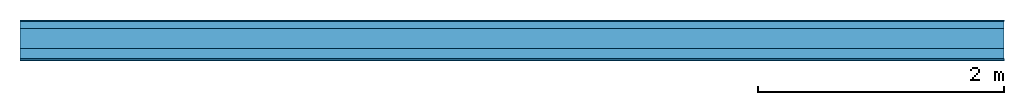
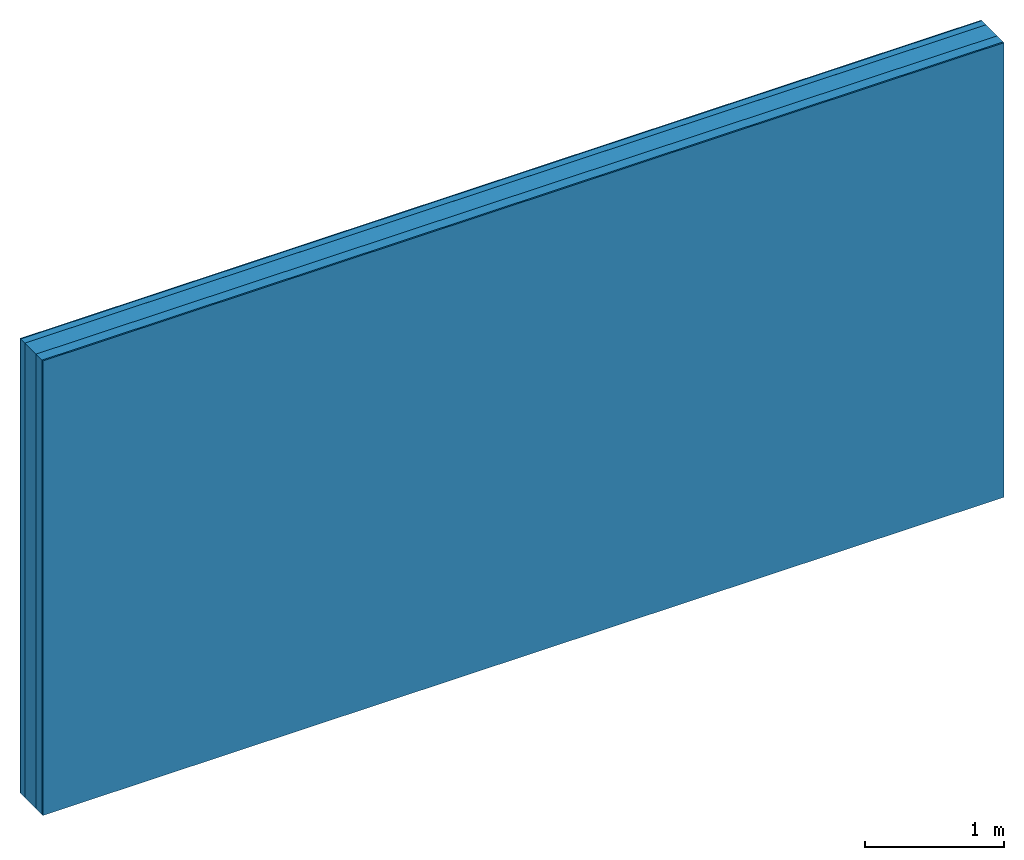
# One storey: 4 plates, 1 member, 1 element without a shape of its own.
"""IFC4 building model written with IfcOpenShell, lengths in metres."""

import ifcopenshell
import ifcopenshell.guid

model = None  # the IFC model being written
_history = None  # IfcOwnerHistory: only IFC2X3 demands one
_inside = {}  # id of a spatial element -> (the spatial element, [elements in it])
_under = {}  # id of a project, library or spatial element -> (it, [spatial elements below it])
_declared = {}  # id of a project -> (the project, [libraries it declares])
_typed = {}  # id of a type object -> (the type object, [elements of that type])
_made_of = {}  # id of a material, layer set ... -> (it, [elements and type objects made of it])


def new_model(schema):
    """Start an empty IFC model of exactly this schema.

    Asked for "IFC4X3", IfcOpenShell would pick the latest addendum, in which some entities
    have other attributes; the version numbers below select the first issue.
    IFC2X3 requires an IfcOwnerHistory on every rooted entity: one is made here for all.
    """
    global model, _history
    if schema == "IFC4X3":
        model = ifcopenshell.file(schema_version=(4, 3, 0, 0))
    else:
        model = ifcopenshell.file(schema=schema)
    _inside.clear()
    _under.clear()
    _declared.clear()
    _typed.clear()
    _made_of.clear()
    _history = None
    if model.schema == "IFC2X3":
        org = make("IfcOrganization", Name="unknown")
        user = make(
            "IfcPersonAndOrganization",
            ThePerson=make("IfcPerson", FamilyName="unknown"),
            TheOrganization=org,
        )
        app = make(
            "IfcApplication",
            ApplicationDeveloper=org,
            Version="unknown",
            ApplicationFullName="unknown",
            ApplicationIdentifier="unknown",
        )
        _history = make(
            "IfcOwnerHistory",
            OwningUser=user,
            OwningApplication=app,
            ChangeAction="ADDED",
            CreationDate=0,
        )
    return model


def make(cls, **values):
    """One entity of the class cls with the attributes given. An attribute that is None is left unset."""
    return model.create_entity(
        cls, **{name: value for name, value in values.items() if value is not None}
    )


def rooted(cls, **values):
    """An entity with a GlobalId (a new one), such as an element, a storey or a relation."""
    return make(cls, GlobalId=ifcopenshell.guid.new(), OwnerHistory=_history, **values)


def si_unit(unit_type, name, prefix=None):
    """IfcSIUnit, for example si_unit("LENGTHUNIT", "METRE", prefix="MILLI")."""
    return make("IfcSIUnit", UnitType=unit_type, Prefix=prefix, Name=name)


def derived_unit(unit_type, elements):
    """IfcDerivedUnit: a product of units, each with its exponent."""
    return make(
        "IfcDerivedUnit",
        Elements=[
            make("IfcDerivedUnitElement", Unit=unit, Exponent=power)
            for unit, power in elements
        ],
        UnitType=unit_type,
    )


def assignment(units):
    """IfcUnitAssignment: the units of a project."""
    return None if units is None else make("IfcUnitAssignment", Units=units)


def point(xyz):
    """IfcCartesianPoint."""
    return None if xyz is None else make("IfcCartesianPoint", Coordinates=xyz)


def direction(xyz):
    """IfcDirection."""
    return None if xyz is None else make("IfcDirection", DirectionRatios=xyz)


def frame(location, z_axis=None, x_axis=None):
    """IfcAxis2Placement3D, a coordinate frame: its origin and axes. An axis left out is left unset."""
    return make(
        "IfcAxis2Placement3D",
        Location=point(location),
        Axis=direction(z_axis),
        RefDirection=direction(x_axis),
    )


def frame_2d(location, x_axis=None):
    """IfcAxis2Placement2D, a coordinate frame in the plane: its origin and x axis."""
    return make(
        "IfcAxis2Placement2D", Location=point(location), RefDirection=direction(x_axis)
    )


def origin():
    """The frame at (0, 0, 0) with its axes left unset."""
    return frame((0.0, 0.0, 0.0))


def origin_with_axes():
    """The frame at (0, 0, 0) with the z axis (0, 0, 1) and the x axis (1, 0, 0) written out."""
    return frame((0.0, 0.0, 0.0), z_axis=(0.0, 0.0, 1.0), x_axis=(1.0, 0.0, 0.0))


def place(relative_to, where):
    """IfcLocalPlacement: puts the frame where relative to a parent placement (None: the world)."""
    return make(
        "IfcLocalPlacement", PlacementRelTo=relative_to, RelativePlacement=where
    )


def context(
    kind, dimensions, precision=None, world=None, true_north=None, identifier=None
):
    """IfcGeometricRepresentationContext, for example the 3D "Model" context."""
    return make(
        "IfcGeometricRepresentationContext",
        ContextIdentifier=identifier,
        ContextType=kind,
        CoordinateSpaceDimension=dimensions,
        Precision=precision,
        WorldCoordinateSystem=world,
        TrueNorth=true_north,
    )


def project(units=None, contexts=None):
    """IfcProject with its units and contexts."""
    return rooted(
        "IfcProject",
        Name="project",
        RepresentationContexts=contexts,
        UnitsInContext=assignment(units),
    )


def spatial(cls, under=None, at=None, **own):
    """A site, building, storey or space (cls), placed at a placement, below another one or the project."""
    s = rooted(cls, ObjectPlacement=at, **own)
    if under is not None:
        _under.setdefault(under.id(), (under, []))[1].append(s)
    return s


def profile(cls, at=None, kind="AREA", **sizes):
    """A parametric profile (cls). Its sizes go by their IFC names, for example OverallWidth=200.0."""
    return make(cls, ProfileType=kind, Position=at, **sizes)


def rectangle(**sizes):
    """IfcRectangleProfileDef."""
    return profile("IfcRectangleProfileDef", **sizes)


def extrude(swept, where, along, depth):
    """IfcExtrudedAreaSolid: the profile swept, set in the frame where, extruded along a direction by depth."""
    return make(
        "IfcExtrudedAreaSolid",
        SweptArea=swept,
        Position=where,
        ExtrudedDirection=direction(along),
        Depth=depth,
    )


def shape(context_of_items, identifier, shape_type, items):
    """IfcShapeRepresentation: the items that make up one representation, for example the "Body"."""
    return make(
        "IfcShapeRepresentation",
        ContextOfItems=context_of_items,
        RepresentationIdentifier=identifier,
        RepresentationType=shape_type,
        Items=items,
    )


def material(Name=None, Category=None):
    """IfcMaterial."""
    return make("IfcMaterial", Name=Name, Category=Category)


def layer(
    of_material, thickness, ventilated=None, Name=None, Category=None, Priority=None
):
    """IfcMaterialLayer: one layer of a wall or slab, of a material (None: an air gap)."""
    return make(
        "IfcMaterialLayer",
        Material=of_material,
        LayerThickness=thickness,
        IsVentilated=ventilated,
        Name=Name,
        Category=Category,
        Priority=Priority,
    )


def layer_set(layers, Name=None):
    """IfcMaterialLayerSet."""
    return make("IfcMaterialLayerSet", MaterialLayers=layers, LayerSetName=Name)


def made_of(thing, what):
    """Note that an element or type object is made of a material, layer set ...; save() writes the relation."""
    if what is not None:
        _made_of.setdefault(what.id(), (what, []))[1].append(thing)
    return thing


def type_object(cls, material=None, **own):
    """A type object (cls), such as IfcWallType, which elements share."""
    return made_of(rooted(cls, **own), material)


def element(
    cls,
    number,
    at=None,
    inside=None,
    cuts=None,
    type_object=None,
    material=None,
    context=None,
    identifier="Body",
    shape_type=None,
    held_by="IfcProductDefinitionShape",
    body=None,
    shapes=None,
    **own,
):
    """One element of the class cls, such as IfcWall. Its Tag is "e" and its number.

    at: its placement. inside: the storey or other place that contains it. cuts: it is an
    opening in that element (IfcRelVoidsElement). A single representation is given by context,
    identifier, shape_type and body (its items); several are given by shapes. held_by: the class
    of the entity that holds the representations. save() writes the other relations.
    """
    e = rooted(cls, Tag="e%d" % number, ObjectPlacement=at, **own)
    if body is not None:
        shapes = [shape(context, identifier, shape_type, body)]
    if shapes is not None:
        e.Representation = make(held_by, Representations=shapes)
    if inside is not None:
        _inside.setdefault(inside.id(), (inside, []))[1].append(e)
    if cuts is not None:
        rooted(
            "IfcRelVoidsElement", RelatingBuildingElement=cuts, RelatedOpeningElement=e
        )
    if type_object is not None:
        _typed.setdefault(type_object.id(), (type_object, []))[1].append(e)
    return made_of(e, material)


def aggregate(whole, parts):
    """IfcRelAggregates: a whole, such as a stair, and the parts it consists of."""
    return rooted("IfcRelAggregates", RelatingObject=whole, RelatedObjects=parts)


def save(model, path):
    """Write the relations noted so far, then the file.

    IfcRelAggregates (storeys below a building ...), IfcRelContainedInSpatialStructure (elements
    in a storey), IfcRelDefinesByType, IfcRelAssociatesMaterial and IfcRelDeclares: one each for
    every whole, place, type object, material and project.
    """
    for whole, parts in _under.values():
        aggregate(whole, parts)
    for where, things in _inside.values():
        rooted(
            "IfcRelContainedInSpatialStructure",
            RelatedElements=things,
            RelatingStructure=where,
        )
    for kind, things in _typed.values():
        rooted("IfcRelDefinesByType", RelatedObjects=things, RelatingType=kind)
    for what, things in _made_of.values():
        rooted("IfcRelAssociatesMaterial", RelatedObjects=things, RelatingMaterial=what)
    for by, libraries in _declared.values():
        rooted("IfcRelDeclares", RelatingContext=by, RelatedDefinitions=libraries)
    model.write(path)


model = new_model("IFC4")

# Units and contexts
plan_context = context("Plan", 3, precision=1e-05, world=origin(), true_north=direction((0.0, 1.0)))
model_context = context("Model", 3, precision=1e-05, world=origin(), true_north=direction((0.0, 1.0)))
ifc_project = project(units=[si_unit("LENGTHUNIT", "METRE"), derived_unit("SOUNDPRESSUREUNIT", [(si_unit("PRESSUREUNIT", "PASCAL", prefix="MICRO"), 0)]), si_unit("ENERGYUNIT", "JOULE", prefix="MEGA"), si_unit("MASSUNIT", "GRAM", prefix="KILO"), derived_unit("THERMALTRANSMITTANCEUNIT", [(si_unit("POWERUNIT", "WATT"), 1), (si_unit("AREAUNIT", "SQUARE_METRE"), -1), (si_unit("THERMODYNAMICTEMPERATUREUNIT", "KELVIN"), -1)]), derived_unit("AREADENSITYUNIT", [(si_unit("MASSUNIT", "GRAM", prefix="KILO"), 1), (si_unit("AREAUNIT", "SQUARE_METRE"), -1)]), derived_unit("USERDEFINED", [(si_unit("ENERGYUNIT", "JOULE", prefix="MEGA"), 1), (si_unit("AREAUNIT", "SQUARE_METRE"), -1)])], contexts=[plan_context, model_context])

# Site, building, storey
site = spatial("IfcSite", under=ifc_project)
building_placement = place(None, origin())
building = spatial("IfcBuilding", under=site, at=building_placement)
storey_placement = place(building_placement, origin())
storey = spatial("IfcBuildingStorey", under=building, at=storey_placement)

# Wall, member, plates
ifc_material_1 = material(Category="04.011")
ifc_layer_1 = layer(ifc_material_1, 0.01, Name="Surface 1")
ifc_material_2 = material(Category="10.009")
ifc_layer_2 = layer(ifc_material_2, 0.06, Name="outside 2nd layer")
ifc_material_3 = material(Category="10.009")
ifc_layer_3 = layer(ifc_material_3, 0.16, Name="outside 1st layer")
ifc_material_4 = material(Name="of the art")
ifc_layer_4 = layer(ifc_material_4, 0.0, Name="Bond")
ifc_layer_5 = layer(None, 0.087, Name="Support")
ifc_layer_6 = layer(ifc_material_4, 0.0, Name="Bond")
ifc_material_5 = material(Name="Plasterboard type A", Category="03.008")
ifc_layer_7 = layer(ifc_material_5, 0.0125, Name="1st layer")
ifc_material_6 = material(Name="joints", Category="04.017")
ifc_layer_8 = layer(ifc_material_6, 0.0, Name="Surface")
ifc_layer_set = layer_set([ifc_layer_1, ifc_layer_2, ifc_layer_3, ifc_layer_4, ifc_layer_5, ifc_layer_6, ifc_layer_7, ifc_layer_8])
wall_type = type_object("IfcWallType", Name="D1031", PredefinedType="NOTDEFINED", material=ifc_layer_set)
wall_placement = place(None, frame((0.0, 0.0, 0.0), z_axis=(0.0, -1.0, 0.0), x_axis=(1.0, 0.0, 0.0)))
wall = element("IfcWall", 1, at=wall_placement, inside=storey, type_object=wall_type, material=ifc_layer_set, Name="Wall #1")
ifc_material_7 = material(Name="Solid timber panel")
member_placement = place(wall_placement, origin())
member = element("IfcMember", 2, at=member_placement, material=ifc_material_7, Name="Support", context=plan_context, shape_type="SweptSolid", body=[
    extrude(rectangle(XDim=1.0, YDim=0.087, at=frame_2d((0.5, 0.0435), x_axis=(1.0, 0.0))), frame((0.0, 4.0, 0.23), z_axis=(0.0, -1.0, 0.0), x_axis=(1.0, 0.0, 0.0)), (0.0, 0.0, 1.0), 4.0),
    extrude(rectangle(XDim=1.0, YDim=0.087, at=frame_2d((0.5, 0.0435), x_axis=(1.0, 0.0))), frame((1.0, 4.0, 0.23), z_axis=(0.0, -1.0, 0.0), x_axis=(1.0, 0.0, 0.0)), (0.0, 0.0, 1.0), 4.0),
    extrude(rectangle(XDim=1.0, YDim=0.087, at=frame_2d((0.5, 0.0435), x_axis=(1.0, 0.0))), frame((2.0, 4.0, 0.23), z_axis=(0.0, -1.0, 0.0), x_axis=(1.0, 0.0, 0.0)), (0.0, 0.0, 1.0), 4.0),
    extrude(rectangle(XDim=1.0, YDim=0.087, at=frame_2d((0.5, 0.0435), x_axis=(1.0, 0.0))), frame((3.0, 4.0, 0.23), z_axis=(0.0, -1.0, 0.0), x_axis=(1.0, 0.0, 0.0)), (0.0, 0.0, 1.0), 4.0),
    extrude(rectangle(XDim=1.0, YDim=0.087, at=frame_2d((0.5, 0.0435), x_axis=(1.0, 0.0))), frame((4.0, 4.0, 0.23), z_axis=(0.0, -1.0, 0.0), x_axis=(1.0, 0.0, 0.0)), (0.0, 0.0, 1.0), 4.0),
    extrude(rectangle(XDim=1.0, YDim=0.087, at=frame_2d((0.5, 0.0435), x_axis=(1.0, 0.0))), frame((5.0, 4.0, 0.23), z_axis=(0.0, -1.0, 0.0), x_axis=(1.0, 0.0, 0.0)), (0.0, 0.0, 1.0), 4.0),
    extrude(rectangle(XDim=1.0, YDim=0.087, at=frame_2d((0.5, 0.0435), x_axis=(1.0, 0.0))), frame((6.0, 4.0, 0.23), z_axis=(0.0, -1.0, 0.0), x_axis=(1.0, 0.0, 0.0)), (0.0, 0.0, 1.0), 4.0),
    extrude(rectangle(XDim=1.0, YDim=0.087, at=frame_2d((0.5, 0.0435), x_axis=(1.0, 0.0))), frame((7.0, 4.0, 0.23), z_axis=(0.0, -1.0, 0.0), x_axis=(1.0, 0.0, 0.0)), (0.0, 0.0, 1.0), 4.0),
])
plate_1_placement = place(wall_placement, origin())
plate_1 = element("IfcPlate", 3, at=plate_1_placement, material=ifc_material_1, Name="Surface 1", context=plan_context, shape_type="SweptSolid", body=[
    extrude(rectangle(XDim=8.0, YDim=4.0, at=frame_2d((4.0, 2.0), x_axis=(1.0, 0.0))), origin_with_axes(), (0.0, 0.0, 1.0), 0.01),
])
plate_2_placement = place(wall_placement, origin())
plate_2 = element("IfcPlate", 4, at=plate_2_placement, material=ifc_material_2, Name="outside 2nd layer", context=plan_context, shape_type="SweptSolid", body=[
    extrude(rectangle(XDim=8.0, YDim=4.0, at=frame_2d((4.0, 2.0), x_axis=(1.0, 0.0))), frame((0.0, 0.0, 0.01), z_axis=(0.0, 0.0, 1.0), x_axis=(1.0, 0.0, 0.0)), (0.0, 0.0, 1.0), 0.06),
])
plate_3_placement = place(wall_placement, origin())
plate_3 = element("IfcPlate", 5, at=plate_3_placement, material=ifc_material_3, Name="outside 1st layer", context=plan_context, shape_type="SweptSolid", body=[
    extrude(rectangle(XDim=8.0, YDim=4.0, at=frame_2d((4.0, 2.0), x_axis=(1.0, 0.0))), frame((0.0, 0.0, 0.07), z_axis=(0.0, 0.0, 1.0), x_axis=(1.0, 0.0, 0.0)), (0.0, 0.0, 1.0), 0.16),
])
plate_4_placement = place(wall_placement, origin())
plate_4 = element("IfcPlate", 6, at=plate_4_placement, material=ifc_material_5, Name="1st layer", context=plan_context, shape_type="SweptSolid", body=[
    extrude(rectangle(XDim=8.0, YDim=4.0, at=frame_2d((4.0, 2.0), x_axis=(1.0, 0.0))), frame((0.0, 0.0, 0.317), z_axis=(0.0, 0.0, 1.0), x_axis=(1.0, 0.0, 0.0)), (0.0, 0.0, 1.0), 0.0125),
])
aggregate(wall, [plate_1, plate_2, plate_3, member, plate_4])

save(model, "model.ifc")
